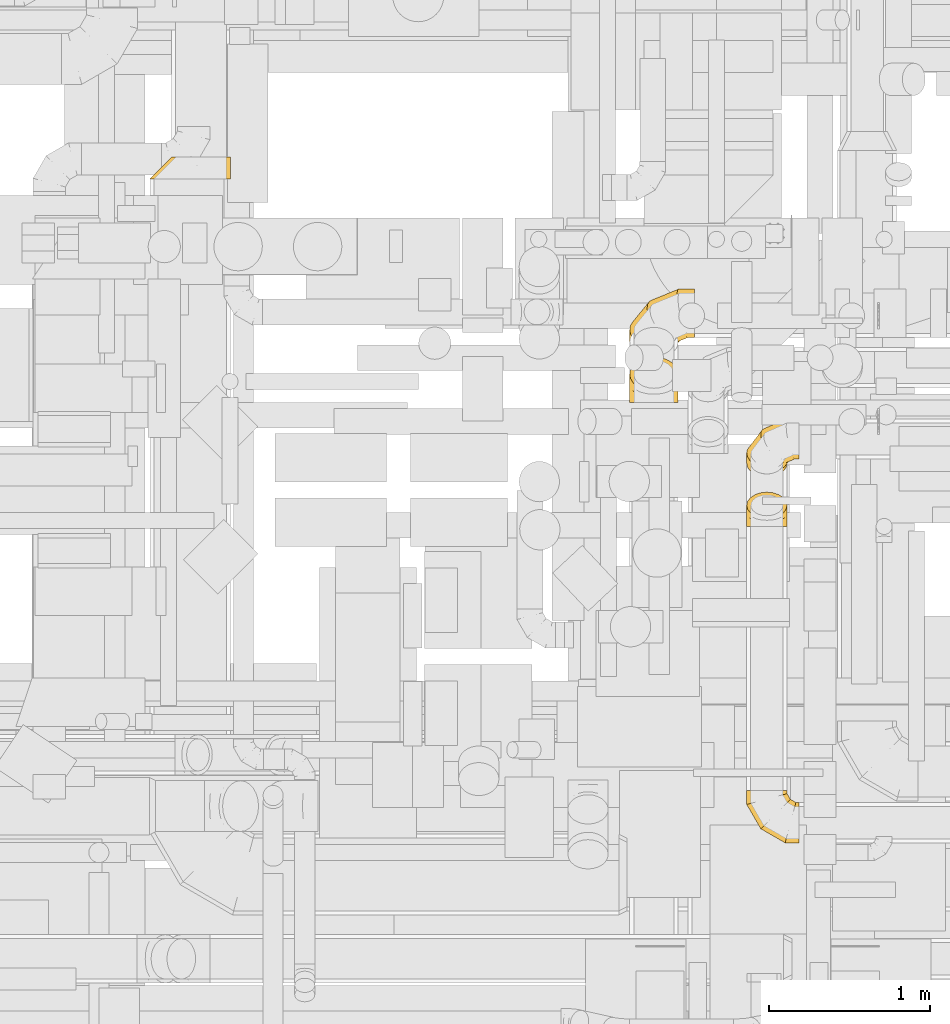
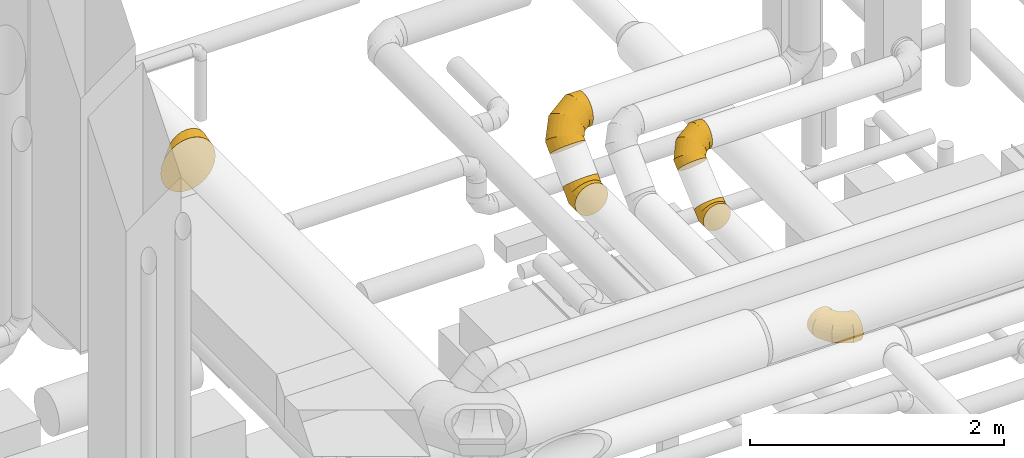
# One storey, part 9 of 337: 6 coverings.
"""IFC2X3 building model written with IfcOpenShell, lengths in millimetres."""

from ifc_helpers import new_model, entity, si_unit, converted_unit, derived_unit, direction, frame, origin, place, context, subcontext, project, spatial, faceted_brep, element, save


model = new_model("IFC2X3")

# Units and contexts
model_context = context("Model", 3, precision=0.01, world=origin(), true_north=direction((6.12303176911189e-17, 1.0)))
body_context = subcontext(model_context, "Body", "Model", "MODEL_VIEW")
ifc_project = project(units=[si_unit("LENGTHUNIT", "METRE", prefix="MILLI"), si_unit("AREAUNIT", "SQUARE_METRE"), si_unit("VOLUMEUNIT", "CUBIC_METRE"), converted_unit("PLANEANGLEUNIT", "DEGREE", entity("IfcRatioMeasure", 0.0174532925199433), si_unit("PLANEANGLEUNIT", "RADIAN"), dimensions=[0, 0, 0, 0, 0, 0, 0]), si_unit("MASSUNIT", "GRAM", prefix="KILO"), derived_unit("MASSDENSITYUNIT", [(si_unit("MASSUNIT", "GRAM", prefix="KILO"), 1), (si_unit("LENGTHUNIT", "METRE"), -3)]), derived_unit("MOMENTOFINERTIAUNIT", [(si_unit("LENGTHUNIT", "METRE"), 4)]), si_unit("TIMEUNIT", "SECOND"), si_unit("FREQUENCYUNIT", "HERTZ"), si_unit("THERMODYNAMICTEMPERATUREUNIT", "DEGREE_CELSIUS"), derived_unit("THERMALTRANSMITTANCEUNIT", [(si_unit("MASSUNIT", "GRAM", prefix="KILO"), 1), (si_unit("THERMODYNAMICTEMPERATUREUNIT", "KELVIN"), -1), (si_unit("TIMEUNIT", "SECOND"), -3)]), derived_unit("VOLUMETRICFLOWRATEUNIT", [(si_unit("LENGTHUNIT", "METRE"), 3), (si_unit("TIMEUNIT", "SECOND"), -1)]), derived_unit("MASSFLOWRATEUNIT", [(si_unit("MASSUNIT", "GRAM", prefix="KILO"), 1), (si_unit("TIMEUNIT", "SECOND"), -1)]), derived_unit("ROTATIONALFREQUENCYUNIT", [(si_unit("TIMEUNIT", "SECOND"), -1)]), si_unit("ELECTRICCURRENTUNIT", "AMPERE"), si_unit("ELECTRICVOLTAGEUNIT", "VOLT"), si_unit("POWERUNIT", "WATT"), si_unit("FORCEUNIT", "NEWTON", prefix="KILO"), si_unit("ILLUMINANCEUNIT", "LUX"), si_unit("LUMINOUSFLUXUNIT", "LUMEN"), si_unit("LUMINOUSINTENSITYUNIT", "CANDELA"), derived_unit("USERDEFINED", [(si_unit("MASSUNIT", "GRAM", prefix="KILO"), -1), (si_unit("LENGTHUNIT", "METRE"), -2), (si_unit("TIMEUNIT", "SECOND"), 3), (si_unit("LUMINOUSFLUXUNIT", "LUMEN"), 1)]), derived_unit("LINEARVELOCITYUNIT", [(si_unit("LENGTHUNIT", "METRE"), 1), (si_unit("TIMEUNIT", "SECOND"), -1)]), si_unit("PRESSUREUNIT", "PASCAL"), derived_unit("USERDEFINED", [(si_unit("LENGTHUNIT", "METRE"), -2), (si_unit("MASSUNIT", "GRAM", prefix="KILO"), 1), (si_unit("TIMEUNIT", "SECOND"), -2)]), derived_unit("LINEARFORCEUNIT", [(si_unit("MASSUNIT", "GRAM", prefix="KILO"), 1), (si_unit("LENGTHUNIT", "METRE"), 1), (si_unit("TIMEUNIT", "SECOND"), -2), (si_unit("LENGTHUNIT", "METRE"), -1)]), derived_unit("PLANARFORCEUNIT", [(si_unit("MASSUNIT", "GRAM", prefix="KILO"), 1), (si_unit("LENGTHUNIT", "METRE"), 1), (si_unit("TIMEUNIT", "SECOND"), -2), (si_unit("LENGTHUNIT", "METRE"), -2)])], contexts=[model_context])

# Site, building, storey
site_placement = place(None, origin())
site = spatial("IfcSite", under=ifc_project, at=site_placement, CompositionType="ELEMENT")
building_placement = place(site_placement, origin())
building = spatial("IfcBuilding", under=site, at=building_placement, CompositionType="ELEMENT")
storey_placement = place(building_placement, origin())
storey = spatial("IfcBuildingStorey", under=building, at=storey_placement, CompositionType="ELEMENT", Elevation=0.0)

# Coverings
covering_1_placement = place(storey_placement, frame((46603.62, 13417.42, 3249.66)))
element("IfcCovering", 1, at=covering_1_placement, inside=storey, PredefinedType="INSULATION", context=body_context, shape_type="Brep", body=[
    faceted_brep([(143.12, 0.0, 476.84), (95.72, 0.0, 447.05), (56.14, 0.0, 407.47), (26.35, 0.0, 360.07), (7.86, 0.0, 307.23), (1.6, 0.0, 251.6), (7.86, 0.0, 195.97), (26.35, 0.0, 143.12), (56.14, 0.0, 95.72), (95.72, 0.0, 56.14), (143.12, 0.0, 26.35), (195.97, 0.0, 7.86), (251.6, 0.0, 1.6), (307.23, 0.0, 7.86), (360.07, 0.0, 26.35), (407.47, 0.0, 56.14), (447.05, 0.0, 95.72), (476.84, 0.0, 143.12), (495.33, 0.0, 195.97), (501.6, 0.0, 251.6), (495.33, 0.0, 307.23), (476.84, 0.0, 360.07), (447.05, 0.0, 407.47), (407.47, 0.0, 447.05), (360.07, 0.0, 476.84), (307.23, 0.0, 495.33), (251.6, 0.0, 501.6), (195.97, 0.0, 495.33), (366.33, 135.0, 477.88), (410.35, 135.0, 459.64), (448.14, 135.0, 430.64), (477.14, 135.0, 392.85), (495.38, 135.0, 348.83), (501.6, 135.0, 301.6), (495.38, 135.0, 254.36), (477.14, 135.0, 210.35), (448.14, 135.0, 172.55), (410.35, 135.0, 143.55), (366.33, 135.0, 125.31), (319.1, 135.0, 119.1), (271.86, 135.0, 125.31), (227.85, 135.0, 143.55), (190.05, 135.0, 172.55), (161.05, 135.0, 210.35), (142.81, 135.0, 254.36), (136.6, 135.0, 301.6), (142.81, 135.0, 348.83), (161.05, 135.0, 392.85), (190.05, 135.0, 430.64), (227.85, 135.0, 459.64), (271.86, 135.0, 477.88), (319.1, 135.0, 484.1), (295.29, 87.4, 77.66), (78.18, 64.36, 203.49), (97.6, 62.48, 158.35), (88.99, 87.4, 283.97), (94.97, 93.38, 286.18), (275.6, 48.01, 43.39), (211.84, 64.36, 69.84), (166.45, 62.48, 89.51), (126.35, 63.75, 123.91), (501.6, 53.25, 271.32), (501.6, 48.01, 269.38), (355.72, 64.36, 69.84), (399.22, 62.48, 89.51), (489.37, 64.36, 203.49), (468.06, 62.48, 158.35), (434.77, 63.75, 118.09), (489.37, 64.36, 347.37), (468.06, 62.48, 391.12), (298.28, 93.38, 489.49), (278.22, 53.25, 494.69), (355.72, 64.36, 481.03), (399.22, 62.48, 459.97), (440.59, 63.75, 426.51), (211.84, 64.36, 481.03), (166.45, 62.48, 459.97), (78.18, 64.36, 347.37), (97.6, 62.48, 391.12), (132.17, 63.75, 432.33)], [[[0, 1, 2, 3, 4, 5, 6, 7, 8, 9, 10, 11, 12, 13, 14, 15, 16, 17, 18, 19, 20, 21, 22, 23, 24, 25, 26, 27]], [[28, 29, 30, 31, 32, 33, 34, 35, 36, 37, 38, 39, 40, 41, 42, 43, 44, 45, 46, 47, 48, 49, 50, 51]], [[52, 40, 39]], [[43, 53, 44]], [[54, 53, 43]], [[55, 44, 53]], [[6, 5, 55]], [[44, 55, 56, 45]], [[11, 52, 57, 12]], [[7, 6, 53]], [[54, 8, 7]], [[58, 10, 59]], [[60, 54, 42]], [[53, 54, 7]], [[59, 60, 42]], [[52, 58, 40]], [[41, 40, 58]], [[55, 53, 6]], [[59, 42, 41]], [[9, 59, 10]], [[60, 59, 9]], [[10, 58, 11]], [[52, 11, 58]], [[9, 8, 60]], [[58, 59, 41]], [[60, 8, 54]], [[42, 54, 43]], [[34, 33, 61, 62]], [[37, 63, 38]], [[64, 63, 37]], [[57, 38, 63]], [[13, 12, 57]], [[38, 57, 52, 39]], [[62, 19, 18]], [[14, 13, 63]], [[64, 15, 14]], [[65, 17, 66]], [[67, 64, 36]], [[63, 64, 14]], [[66, 67, 36]], [[62, 65, 34]], [[35, 34, 65]], [[57, 63, 13]], [[66, 36, 35]], [[16, 66, 17]], [[67, 66, 16]], [[17, 65, 18]], [[62, 18, 65]], [[16, 15, 67]], [[65, 66, 35]], [[67, 15, 64]], [[36, 64, 37]], [[61, 68, 20]], [[31, 68, 32]], [[69, 68, 31]], [[61, 32, 68]], [[20, 19, 62, 61]], [[33, 32, 61]], [[28, 51, 70, 71]], [[22, 21, 69]], [[20, 68, 21]], [[72, 24, 73]], [[74, 69, 30]], [[73, 30, 29]], [[73, 74, 30]], [[71, 72, 28]], [[29, 28, 72]], [[30, 69, 31]], [[71, 26, 25]], [[68, 69, 21]], [[23, 73, 24]], [[72, 73, 29]], [[24, 72, 25]], [[71, 25, 72]], [[74, 73, 23]], [[74, 22, 69]], [[23, 22, 74]], [[56, 46, 45]], [[49, 75, 50]], [[76, 75, 49]], [[70, 50, 75]], [[27, 26, 71, 70]], [[51, 50, 70]], [[4, 56, 55, 5]], [[0, 27, 75]], [[76, 1, 0]], [[77, 3, 78]], [[79, 76, 48]], [[75, 76, 0]], [[78, 79, 48]], [[56, 77, 46]], [[47, 46, 77]], [[70, 75, 27]], [[78, 48, 47]], [[2, 78, 3]], [[79, 78, 2]], [[3, 77, 4]], [[56, 4, 77]], [[2, 1, 79]], [[77, 78, 47]], [[79, 1, 76]], [[48, 76, 49]]]),
])
covering_2_placement = place(storey_placement, frame((50300.56, 9303.36, 2923.4)))
element("IfcCovering", 2, at=covering_2_placement, inside=storey, PredefinedType="INSULATION", context=body_context, shape_type="Brep", body=[
    faceted_brep([(326.6, 165.22, 245.48), (326.6, 126.6, 251.6), (326.6, 87.97, 245.48), (326.6, 53.12, 227.72), (326.6, 25.47, 200.07), (326.6, 7.71, 165.22), (326.6, 1.6, 126.6), (326.6, 7.71, 87.97), (326.6, 25.47, 53.12), (326.6, 53.12, 25.47), (326.6, 87.97, 7.71), (326.6, 126.6, 1.6), (326.6, 165.22, 7.71), (326.6, 200.07, 25.47), (326.6, 227.72, 53.12), (326.6, 245.48, 87.97), (326.6, 251.6, 126.6), (326.6, 245.48, 165.22), (326.6, 227.72, 200.07), (326.6, 200.07, 227.72), (18.34, 326.6, 64.1), (5.85, 326.6, 94.24), (1.6, 326.6, 126.6), (5.85, 326.6, 158.95), (18.34, 326.6, 189.1), (38.21, 326.6, 214.98), (64.1, 326.6, 234.85), (94.24, 326.6, 247.34), (126.6, 326.6, 251.6), (158.95, 326.6, 247.34), (189.1, 326.6, 234.85), (214.98, 326.6, 214.98), (234.85, 326.6, 189.1), (247.34, 326.6, 158.95), (251.6, 326.6, 126.6), (247.34, 326.6, 94.24), (234.85, 326.6, 64.1), (214.98, 326.6, 38.21), (189.1, 326.6, 18.34), (158.95, 326.6, 5.85), (126.6, 326.6, 1.6), (94.24, 326.6, 5.85), (64.1, 326.6, 18.34), (38.21, 326.6, 38.21), (1.6, 239.51, 126.6), (5.85, 240.65, 158.95), (18.34, 244.0, 189.1), (38.21, 249.32, 214.98), (64.1, 256.26, 234.85), (94.24, 264.34, 247.34), (126.6, 273.01, 251.6), (158.95, 281.67, 247.34), (189.1, 289.75, 234.85), (214.98, 296.69, 214.98), (234.85, 302.01, 189.1), (247.34, 305.36, 158.95), (251.6, 306.5, 126.6), (247.34, 305.36, 94.24), (234.85, 302.01, 64.1), (214.98, 296.69, 38.21), (158.95, 281.67, 5.85), (126.6, 273.01, 1.6), (189.1, 289.75, 18.34), (94.24, 264.34, 5.85), (64.1, 256.26, 18.34), (38.21, 249.32, 38.21), (18.34, 244.0, 64.1), (5.85, 240.65, 94.24), (88.68, 88.68, 126.6), (91.8, 91.8, 158.95), (100.94, 100.94, 189.1), (115.48, 115.48, 214.98), (134.43, 134.43, 234.85), (156.5, 156.5, 247.34), (180.19, 180.19, 251.6), (203.87, 203.87, 247.34), (225.94, 225.94, 234.85), (244.89, 244.89, 214.98), (259.43, 259.43, 189.1), (268.57, 268.57, 158.95), (271.69, 271.69, 126.6), (268.57, 268.57, 94.24), (259.43, 259.43, 64.1), (244.89, 244.89, 38.21), (203.87, 203.87, 5.85), (180.19, 180.19, 1.6), (225.94, 225.94, 18.34), (156.5, 156.5, 5.85), (134.43, 134.43, 18.34), (115.48, 115.48, 38.21), (100.94, 100.94, 64.1), (91.8, 91.8, 94.24), (239.51, 1.6, 126.6), (240.65, 5.85, 158.95), (244.0, 18.34, 189.1), (249.32, 38.21, 214.98), (256.26, 64.1, 234.85), (264.34, 94.24, 247.34), (273.01, 126.6, 251.6), (281.67, 158.95, 247.34), (289.75, 189.1, 234.85), (296.69, 214.98, 214.98), (302.01, 234.85, 189.1), (305.36, 247.34, 158.95), (306.5, 251.6, 126.6), (305.36, 247.34, 94.24), (302.01, 234.85, 64.1), (296.69, 214.98, 38.21), (281.67, 158.95, 5.85), (273.01, 126.6, 1.6), (289.75, 189.1, 18.34), (264.34, 94.24, 5.85), (256.26, 64.1, 18.34), (249.32, 38.21, 38.21), (244.0, 18.34, 64.1), (240.65, 5.85, 94.24)], [[[0, 1, 2, 3, 4, 5, 6, 7, 8, 9, 10, 11, 12, 13, 14, 15, 16, 17, 18, 19]], [[20, 21, 22, 23, 24, 25, 26, 27, 28, 29, 30, 31, 32, 33, 34, 35, 36, 37, 38, 39, 40, 41, 42, 43]], [[22, 44, 45, 23]], [[23, 45, 46, 24]], [[47, 25, 24, 46]], [[25, 47, 48, 26]], [[26, 48, 49, 27]], [[50, 28, 27, 49]], [[51, 52, 30, 29]], [[50, 51, 29, 28]], [[53, 31, 30, 52]], [[54, 55, 33, 32]], [[54, 32, 31, 53]], [[56, 34, 33, 55]], [[57, 58, 36, 35]], [[56, 57, 35, 34]], [[37, 36, 58, 59]], [[60, 61, 40, 39]], [[62, 60, 39, 38]], [[59, 62, 38, 37]], [[41, 40, 61, 63]], [[42, 41, 63, 64]], [[64, 65, 43, 42]], [[21, 20, 66, 67]], [[22, 21, 67, 44]], [[65, 66, 20, 43]], [[45, 44, 68, 69]], [[46, 45, 69, 70]], [[70, 71, 47, 46]], [[48, 47, 71, 72]], [[49, 48, 72, 73]], [[50, 49, 73, 74]], [[75, 76, 52, 51]], [[74, 75, 51, 50]], [[53, 52, 76, 77]], [[78, 79, 55, 54]], [[77, 78, 54, 53]], [[56, 55, 79, 80]], [[81, 82, 58, 57]], [[80, 81, 57, 56]], [[59, 58, 82, 83]], [[84, 85, 61, 60]], [[86, 84, 60, 62]], [[83, 86, 62, 59]], [[63, 61, 85, 87]], [[64, 63, 87, 88]], [[65, 64, 88, 89]], [[67, 66, 90, 91]], [[44, 67, 91, 68]], [[89, 90, 66, 65]], [[69, 68, 92, 93]], [[70, 69, 93, 94]], [[94, 95, 71, 70]], [[72, 71, 95, 96]], [[73, 72, 96, 97]], [[74, 73, 97, 98]], [[99, 100, 76, 75]], [[98, 99, 75, 74]], [[77, 76, 100, 101]], [[102, 103, 79, 78]], [[101, 102, 78, 77]], [[80, 79, 103, 104]], [[105, 106, 82, 81]], [[104, 105, 81, 80]], [[83, 82, 106, 107]], [[108, 109, 85, 84]], [[110, 108, 84, 86]], [[107, 110, 86, 83]], [[87, 85, 109, 111]], [[88, 87, 111, 112]], [[89, 88, 112, 113]], [[91, 90, 114, 115]], [[68, 91, 115, 92]], [[113, 114, 90, 89]], [[93, 6, 5]], [[94, 5, 4]], [[6, 93, 92]], [[93, 5, 94]], [[4, 95, 94]], [[96, 3, 2]], [[97, 2, 1]], [[95, 3, 96]], [[96, 2, 97]], [[1, 98, 97]], [[3, 95, 4]], [[99, 1, 0]], [[100, 0, 19]], [[99, 98, 1]], [[100, 99, 0]], [[19, 101, 100]], [[17, 16, 103]], [[18, 17, 102]], [[102, 101, 18]], [[104, 103, 16]], [[102, 17, 103]], [[18, 101, 19]], [[105, 16, 15]], [[106, 15, 14]], [[105, 104, 16]], [[106, 105, 15]], [[14, 107, 106]], [[110, 13, 12]], [[108, 12, 11]], [[110, 107, 13]], [[109, 108, 11]], [[110, 12, 108]], [[13, 107, 14]], [[111, 11, 10]], [[112, 10, 9]], [[11, 111, 109]], [[111, 10, 112]], [[9, 113, 112]], [[114, 8, 7]], [[115, 7, 6]], [[113, 8, 114]], [[115, 114, 7]], [[92, 115, 6]], [[8, 113, 9]]]),
])
covering_3_placement = place(storey_placement, frame((49575.95, 12032.2, 2848.4)))
element("IfcCovering", 3, at=covering_3_placement, inside=storey, PredefinedType="INSULATION", context=body_context, shape_type="Brep", body=[
    faceted_brep([(151.6, 70.71, 330.88), (190.42, 74.32, 327.27), (226.6, 84.92, 316.67), (257.66, 101.78, 299.82), (281.5, 123.74, 277.85), (296.48, 149.32, 252.27), (301.6, 176.78, 224.82), (296.48, 204.23, 197.37), (281.5, 229.81, 171.79), (257.66, 251.78, 149.82), (226.6, 268.63, 132.96), (190.42, 279.23, 122.37), (151.6, 282.84, 118.75), (112.77, 279.23, 122.37), (76.6, 268.63, 132.96), (45.53, 251.78, 149.82), (21.69, 229.81, 171.79), (6.71, 204.23, 197.37), (1.6, 176.78, 224.82), (6.71, 149.32, 252.27), (21.69, 123.74, 277.85), (45.53, 101.78, 299.82), (76.6, 84.92, 316.67), (112.77, 74.32, 327.27), (76.6, 0.0, 21.69), (112.77, 0.0, 6.71), (151.6, 0.0, 1.6), (190.42, 0.0, 6.71), (226.6, 0.0, 21.69), (257.66, 0.0, 45.53), (281.5, 0.0, 76.6), (296.48, 0.0, 112.77), (301.6, 0.0, 151.6), (296.48, 0.0, 190.42), (281.5, 0.0, 226.6), (257.66, 0.0, 257.66), (226.6, 0.0, 281.5), (190.42, 0.0, 296.48), (151.6, 0.0, 301.6), (112.77, 0.0, 296.48), (76.6, 0.0, 281.5), (45.53, 0.0, 257.66), (21.69, 0.0, 226.6), (6.71, 0.0, 190.42), (1.6, 0.0, 151.6), (6.71, 0.0, 112.77), (21.69, 0.0, 76.6), (45.53, 0.0, 45.53), (151.6, 165.69, 1.6), (190.42, 163.57, 6.71), (226.6, 157.36, 21.69), (257.66, 147.49, 45.53), (281.5, 134.62, 76.6), (296.48, 119.63, 112.77), (301.6, 103.55, 151.6), (296.48, 87.47, 190.42), (281.5, 72.49, 226.6), (257.66, 59.62, 257.66), (190.42, 43.54, 296.48), (151.6, 41.42, 301.6), (226.6, 49.75, 281.5), (76.6, 49.75, 281.5), (45.53, 59.62, 257.66), (112.77, 43.54, 296.48), (6.71, 87.47, 190.42), (1.6, 103.55, 151.6), (21.69, 72.49, 226.6), (6.71, 119.63, 112.77), (21.69, 134.62, 76.6), (45.53, 147.49, 45.53), (76.6, 157.36, 21.69), (112.77, 163.57, 6.71)], [[[0, 1, 2, 3, 4, 5, 6, 7, 8, 9, 10, 11, 12, 13, 14, 15, 16, 17, 18, 19, 20, 21, 22, 23]], [[24, 25, 26, 27, 28, 29, 30, 31, 32, 33, 34, 35, 36, 37, 38, 39, 40, 41, 42, 43, 44, 45, 46, 47]], [[26, 48, 49, 27]], [[27, 49, 50, 28]], [[51, 29, 28, 50]], [[29, 51, 52, 30]], [[30, 52, 53, 31]], [[54, 32, 31, 53]], [[55, 56, 34, 33]], [[54, 55, 33, 32]], [[34, 56, 57, 35]], [[58, 59, 38, 37]], [[60, 58, 37, 36]], [[35, 57, 60, 36]], [[40, 61, 62, 41]], [[63, 61, 40, 39]], [[38, 59, 63, 39]], [[64, 65, 44, 43]], [[66, 64, 43, 42]], [[62, 66, 42, 41]], [[45, 44, 65, 67]], [[46, 45, 67, 68]], [[68, 69, 47, 46]], [[25, 24, 70, 71]], [[26, 25, 71, 48]], [[69, 70, 24, 47]], [[11, 10, 50, 49]], [[12, 11, 49, 48]], [[10, 9, 51, 50]], [[53, 52, 8, 7]], [[54, 53, 7, 6]], [[9, 8, 52, 51]], [[5, 4, 56, 55]], [[6, 5, 55, 54]], [[57, 56, 4, 3]], [[58, 60, 2, 1]], [[59, 58, 1, 0]], [[3, 2, 60, 57]], [[59, 0, 23, 63]], [[63, 23, 22, 61]], [[21, 62, 61, 22]], [[66, 20, 19, 64]], [[64, 19, 18, 65]], [[20, 66, 62, 21]], [[65, 18, 17, 67]], [[67, 17, 16, 68]], [[15, 69, 68, 16]], [[70, 14, 13, 71]], [[71, 13, 12, 48]], [[14, 70, 69, 15]]]),
])
covering_4_placement = place(storey_placement, frame((49575.95, 12301.32, 3165.56)))
element("IfcCovering", 4, at=covering_4_placement, inside=storey, PredefinedType="INSULATION", context=body_context, shape_type="Brep", body=[
    faceted_brep([(151.6, 1.6, 213.73), (112.77, 5.21, 210.11), (76.6, 15.81, 199.52), (45.53, 32.66, 182.66), (21.69, 54.63, 160.69), (6.71, 80.21, 135.11), (1.6, 107.66, 107.66), (6.71, 135.11, 80.21), (21.69, 160.69, 54.63), (45.53, 182.66, 32.66), (76.6, 199.52, 15.81), (112.77, 210.11, 5.21), (151.6, 213.73, 1.6), (190.42, 210.11, 5.21), (226.6, 199.52, 15.81), (257.66, 182.66, 32.66), (281.5, 160.69, 54.63), (296.48, 135.11, 80.21), (301.6, 107.66, 107.66), (296.48, 80.21, 135.11), (281.5, 54.63, 160.69), (257.66, 32.66, 182.66), (226.6, 15.81, 199.52), (190.42, 5.21, 210.11), (401.6, 414.34, 359.44), (401.6, 390.5, 390.5), (401.6, 359.44, 414.34), (401.6, 323.26, 429.33), (401.6, 284.44, 434.44), (401.6, 245.62, 429.33), (401.6, 209.44, 414.34), (401.6, 178.37, 390.5), (401.6, 154.53, 359.44), (401.6, 139.55, 323.26), (401.6, 134.44, 284.44), (401.6, 139.55, 245.62), (401.6, 154.53, 209.44), (401.6, 178.37, 178.37), (401.6, 209.44, 154.53), (401.6, 245.62, 139.55), (401.6, 284.44, 134.44), (401.6, 323.26, 139.55), (401.6, 359.44, 154.53), (401.6, 390.5, 178.37), (401.6, 414.34, 209.44), (401.6, 429.33, 245.62), (401.6, 434.44, 284.44), (401.6, 429.33, 323.26), (294.42, 390.5, 390.5), (295.79, 359.44, 414.34), (299.8, 323.26, 429.33), (306.19, 284.44, 434.44), (314.51, 245.62, 429.33), (324.21, 209.44, 414.34), (334.61, 178.37, 390.5), (345.01, 154.53, 359.44), (354.7, 139.55, 323.26), (363.03, 134.44, 284.44), (369.42, 139.55, 245.62), (373.43, 154.53, 209.44), (374.8, 178.37, 178.37), (373.43, 209.44, 154.53), (369.42, 245.62, 139.55), (363.03, 284.44, 134.44), (345.01, 359.44, 154.53), (334.61, 390.5, 178.37), (354.7, 323.26, 139.55), (324.21, 414.34, 209.44), (314.51, 429.33, 245.62), (306.19, 434.44, 284.44), (299.8, 429.33, 323.26), (295.79, 414.34, 359.44), (108.77, 314.72, 314.72), (112.52, 284.62, 339.52), (123.49, 251.28, 357.35), (140.94, 216.97, 366.97), (163.68, 184.04, 367.75), (190.16, 154.72, 359.62), (218.58, 131.0, 343.14), (247.0, 114.52, 319.43), (273.49, 106.39, 290.1), (296.23, 107.17, 257.17), (313.68, 116.79, 222.86), (324.65, 134.62, 189.52), (328.39, 159.43, 159.43), (324.65, 189.52, 134.62), (313.68, 222.86, 116.79), (296.23, 257.17, 107.17), (247.0, 319.43, 114.52), (218.58, 343.14, 131.0), (273.49, 290.1, 106.39), (190.16, 359.62, 154.72), (163.68, 367.75, 184.04), (140.94, 366.97, 216.97), (123.49, 357.35, 251.28), (112.52, 339.52, 284.62), (1.6, 183.45, 183.45), (6.71, 155.03, 209.93), (21.69, 126.61, 232.67), (45.53, 100.12, 250.12), (76.6, 77.38, 261.09), (112.77, 59.93, 264.84), (151.6, 48.96, 261.09), (190.42, 45.22, 250.12), (226.6, 48.96, 232.67), (257.66, 59.93, 209.93), (281.5, 77.38, 183.45), (296.48, 100.12, 155.03), (301.6, 126.61, 126.61), (296.48, 155.03, 100.12), (281.5, 183.45, 77.38), (257.66, 209.93, 59.93), (190.42, 250.12, 45.22), (151.6, 261.09, 48.96), (226.6, 232.67, 48.96), (112.77, 264.84, 59.93), (76.6, 261.09, 77.38), (45.53, 250.12, 100.12), (21.69, 232.67, 126.61), (6.71, 209.93, 155.03)], [[[0, 1, 2, 3, 4, 5, 6, 7, 8, 9, 10, 11, 12, 13, 14, 15, 16, 17, 18, 19, 20, 21, 22, 23]], [[24, 25, 26, 27, 28, 29, 30, 31, 32, 33, 34, 35, 36, 37, 38, 39, 40, 41, 42, 43, 44, 45, 46, 47]], [[25, 48, 49, 26]], [[26, 49, 50, 27]], [[51, 28, 27, 50]], [[28, 51, 52, 29]], [[29, 52, 53, 30]], [[54, 31, 30, 53]], [[55, 56, 33, 32]], [[54, 55, 32, 31]], [[57, 34, 33, 56]], [[58, 59, 36, 35]], [[58, 35, 34, 57]], [[60, 37, 36, 59]], [[61, 62, 39, 38]], [[60, 61, 38, 37]], [[40, 39, 62, 63]], [[64, 65, 43, 42]], [[66, 64, 42, 41]], [[63, 66, 41, 40]], [[44, 43, 65, 67]], [[45, 44, 67, 68]], [[68, 69, 46, 45]], [[24, 47, 70, 71]], [[25, 24, 71, 48]], [[69, 70, 47, 46]], [[49, 48, 72, 73]], [[50, 49, 73, 74]], [[74, 75, 51, 50]], [[52, 51, 75, 76]], [[53, 52, 76, 77]], [[54, 53, 77, 78]], [[79, 80, 56, 55]], [[78, 79, 55, 54]], [[57, 56, 80, 81]], [[82, 83, 59, 58]], [[81, 82, 58, 57]], [[60, 59, 83, 84]], [[85, 86, 62, 61]], [[84, 85, 61, 60]], [[63, 62, 86, 87]], [[88, 89, 65, 64]], [[90, 88, 64, 66]], [[87, 90, 66, 63]], [[67, 65, 89, 91]], [[68, 67, 91, 92]], [[69, 68, 92, 93]], [[71, 70, 94, 95]], [[48, 71, 95, 72]], [[93, 94, 70, 69]], [[73, 72, 96, 97]], [[74, 73, 97, 98]], [[98, 99, 75, 74]], [[76, 75, 99, 100]], [[77, 76, 100, 101]], [[78, 77, 101, 102]], [[103, 104, 80, 79]], [[102, 103, 79, 78]], [[81, 80, 104, 105]], [[106, 107, 83, 82]], [[105, 106, 82, 81]], [[84, 83, 107, 108]], [[109, 110, 86, 85]], [[108, 109, 85, 84]], [[87, 86, 110, 111]], [[112, 113, 89, 88]], [[114, 112, 88, 90]], [[111, 114, 90, 87]], [[91, 89, 113, 115]], [[92, 91, 115, 116]], [[93, 92, 116, 117]], [[95, 94, 118, 119]], [[72, 95, 119, 96]], [[117, 118, 94, 93]], [[97, 96, 6, 5]], [[98, 97, 5, 4]], [[4, 3, 99, 98]], [[101, 100, 2, 1]], [[102, 101, 1, 0]], [[3, 2, 100, 99]], [[103, 102, 0, 23]], [[104, 103, 23, 22]], [[105, 104, 22, 21]], [[107, 106, 20, 19]], [[108, 107, 19, 18]], [[105, 21, 20, 106]], [[108, 18, 17, 109]], [[109, 17, 16, 110]], [[110, 16, 15, 111]], [[13, 12, 113, 112]], [[14, 13, 112, 114]], [[114, 111, 15, 14]], [[113, 12, 11, 115]], [[115, 11, 10, 116]], [[9, 117, 116, 10]], [[118, 8, 7, 119]], [[119, 7, 6, 96]], [[8, 118, 117, 9]]]),
])
covering_5_placement = place(storey_placement, frame((50300.56, 11572.15, 3223.36)))
element("IfcCovering", 5, at=covering_5_placement, inside=storey, PredefinedType="INSULATION", context=body_context, shape_type="Brep", body=[
    faceted_brep([(200.07, 17.13, 173.34), (165.22, 5.58, 186.82), (126.6, 1.6, 191.47), (87.97, 5.58, 186.82), (53.12, 17.13, 173.34), (25.47, 35.11, 152.33), (7.71, 57.78, 125.87), (1.6, 82.91, 96.53), (7.71, 108.04, 67.19), (25.47, 130.71, 40.73), (53.12, 148.7, 19.73), (87.97, 160.25, 6.24), (126.6, 164.23, 1.6), (165.22, 160.25, 6.24), (200.07, 148.7, 19.73), (227.72, 130.71, 40.73), (245.48, 108.04, 67.19), (251.6, 82.91, 96.53), (245.48, 57.78, 125.87), (227.72, 35.11, 152.33), (326.6, 357.68, 249.59), (326.6, 347.55, 280.61), (326.6, 329.74, 307.95), (326.6, 305.46, 329.75), (326.6, 276.37, 344.52), (326.6, 244.44, 351.26), (326.6, 211.85, 349.51), (326.6, 180.83, 339.38), (326.6, 153.49, 321.57), (326.6, 131.69, 297.29), (326.6, 116.92, 268.19), (326.6, 110.18, 236.27), (326.6, 111.93, 203.68), (326.6, 122.06, 172.66), (326.6, 139.87, 145.32), (326.6, 164.15, 123.52), (326.6, 193.25, 108.75), (326.6, 225.18, 102.01), (326.6, 257.76, 103.76), (326.6, 288.78, 113.89), (326.6, 316.12, 131.7), (326.6, 337.92, 155.98), (326.6, 352.7, 185.08), (326.6, 359.44, 217.0), (239.51, 329.74, 307.95), (240.65, 305.46, 329.75), (244.0, 276.37, 344.52), (249.32, 244.44, 351.26), (256.26, 211.85, 349.51), (264.34, 180.83, 339.38), (273.01, 153.49, 321.57), (281.67, 131.69, 297.29), (289.75, 116.92, 268.19), (296.69, 110.18, 236.27), (302.01, 111.93, 203.68), (305.36, 122.06, 172.66), (306.5, 139.87, 145.32), (305.36, 164.15, 123.52), (302.01, 193.25, 108.75), (296.69, 225.18, 102.01), (281.67, 288.78, 113.89), (273.01, 316.12, 131.7), (289.75, 257.76, 103.76), (264.34, 337.92, 155.98), (256.26, 352.7, 185.08), (249.32, 359.44, 217.0), (244.0, 357.68, 249.59), (240.65, 347.55, 280.61), (88.68, 263.61, 251.3), (91.8, 240.19, 273.84), (100.94, 213.64, 290.79), (115.48, 185.75, 301.0), (134.43, 158.44, 303.75), (156.5, 133.55, 298.88), (180.19, 112.79, 286.71), (203.87, 97.58, 268.07), (225.94, 88.94, 244.23), (244.89, 87.47, 216.81), (259.43, 93.26, 187.69), (268.57, 105.93, 158.85), (271.69, 124.61, 132.25), (268.57, 148.02, 109.7), (259.43, 174.58, 92.75), (244.89, 202.46, 82.55), (203.87, 254.66, 84.67), (180.19, 275.42, 96.84), (225.94, 229.78, 79.79), (156.5, 290.64, 115.48), (134.43, 299.28, 139.32), (115.48, 300.75, 166.74), (100.94, 294.95, 195.86), (91.8, 282.28, 224.7), (1.6, 149.05, 153.18), (5.85, 127.14, 177.01), (18.34, 104.98, 197.73), (38.21, 84.1, 213.93), (64.1, 65.91, 224.5), (94.24, 51.65, 228.73), (126.6, 42.3, 226.33), (158.95, 38.48, 217.45), (189.1, 40.47, 202.72), (214.98, 48.13, 183.12), (234.85, 60.92, 159.99), (247.34, 77.99, 134.92), (251.6, 98.17, 109.6), (247.34, 120.09, 85.78), (234.85, 142.24, 65.06), (214.98, 163.12, 48.86), (158.95, 195.57, 34.05), (126.6, 204.93, 36.46), (189.1, 181.31, 38.28), (94.24, 208.74, 45.33), (64.1, 206.75, 60.07), (38.21, 199.1, 79.67), (18.34, 186.3, 102.79), (5.85, 169.23, 127.87)], [[[0, 1, 2, 3, 4, 5, 6, 7, 8, 9, 10, 11, 12, 13, 14, 15, 16, 17, 18, 19]], [[20, 21, 22, 23, 24, 25, 26, 27, 28, 29, 30, 31, 32, 33, 34, 35, 36, 37, 38, 39, 40, 41, 42, 43]], [[22, 44, 45, 23]], [[23, 45, 46, 24]], [[47, 25, 24, 46]], [[25, 47, 48, 26]], [[26, 48, 49, 27]], [[50, 28, 27, 49]], [[51, 52, 30, 29]], [[50, 51, 29, 28]], [[53, 31, 30, 52]], [[54, 55, 33, 32]], [[54, 32, 31, 53]], [[56, 34, 33, 55]], [[57, 58, 36, 35]], [[56, 57, 35, 34]], [[37, 36, 58, 59]], [[60, 61, 40, 39]], [[62, 60, 39, 38]], [[59, 62, 38, 37]], [[41, 40, 61, 63]], [[42, 41, 63, 64]], [[64, 65, 43, 42]], [[21, 20, 66, 67]], [[22, 21, 67, 44]], [[65, 66, 20, 43]], [[45, 44, 68, 69]], [[46, 45, 69, 70]], [[70, 71, 47, 46]], [[48, 47, 71, 72]], [[49, 48, 72, 73]], [[50, 49, 73, 74]], [[75, 76, 52, 51]], [[74, 75, 51, 50]], [[53, 52, 76, 77]], [[78, 79, 55, 54]], [[77, 78, 54, 53]], [[56, 55, 79, 80]], [[81, 82, 58, 57]], [[80, 81, 57, 56]], [[59, 58, 82, 83]], [[84, 85, 61, 60]], [[86, 84, 60, 62]], [[83, 86, 62, 59]], [[63, 61, 85, 87]], [[64, 63, 87, 88]], [[65, 64, 88, 89]], [[67, 66, 90, 91]], [[44, 67, 91, 68]], [[89, 90, 66, 65]], [[69, 68, 92, 93]], [[70, 69, 93, 94]], [[94, 95, 71, 70]], [[72, 71, 95, 96]], [[73, 72, 96, 97]], [[74, 73, 97, 98]], [[99, 100, 76, 75]], [[98, 99, 75, 74]], [[77, 76, 100, 101]], [[102, 103, 79, 78]], [[101, 102, 78, 77]], [[80, 79, 103, 104]], [[105, 106, 82, 81]], [[104, 105, 81, 80]], [[83, 82, 106, 107]], [[108, 109, 85, 84]], [[110, 108, 84, 86]], [[107, 110, 86, 83]], [[87, 85, 109, 111]], [[88, 87, 111, 112]], [[89, 88, 112, 113]], [[91, 90, 114, 115]], [[68, 91, 115, 92]], [[113, 114, 90, 89]], [[93, 7, 6]], [[94, 6, 5]], [[7, 93, 92]], [[93, 6, 94]], [[5, 95, 94]], [[96, 4, 3]], [[97, 3, 2]], [[95, 4, 96]], [[96, 3, 97]], [[2, 98, 97]], [[4, 95, 5]], [[99, 2, 1]], [[100, 1, 0]], [[99, 98, 2]], [[100, 99, 1]], [[0, 101, 100]], [[18, 17, 103]], [[19, 18, 102]], [[102, 101, 19]], [[104, 103, 17]], [[102, 18, 103]], [[19, 101, 0]], [[105, 17, 16]], [[106, 16, 15]], [[105, 104, 17]], [[106, 105, 16]], [[15, 107, 106]], [[110, 14, 13]], [[108, 13, 12]], [[110, 107, 14]], [[109, 108, 12]], [[110, 13, 108]], [[14, 107, 15]], [[111, 12, 11]], [[112, 11, 10]], [[12, 111, 109]], [[111, 11, 112]], [[10, 113, 112]], [[114, 9, 8]], [[115, 8, 7]], [[113, 9, 114]], [[115, 114, 8]], [[92, 115, 7]], [[9, 113, 10]]]),
])
covering_6_placement = place(storey_placement, frame((50300.56, 11266.01, 2923.4)))
element("IfcCovering", 6, at=covering_6_placement, inside=storey, PredefinedType="INSULATION", context=body_context, shape_type="Brep", body=[
    faceted_brep([(1.6, 130.1, 174.7), (7.71, 104.98, 204.03), (25.47, 82.31, 230.5), (53.12, 64.32, 251.5), (87.97, 52.77, 264.99), (126.6, 48.79, 269.63), (165.22, 52.77, 264.99), (200.07, 64.32, 251.5), (227.72, 82.31, 230.5), (245.48, 104.98, 204.03), (251.6, 130.1, 174.7), (245.48, 155.23, 145.36), (227.72, 177.9, 118.9), (200.07, 195.89, 97.89), (165.22, 207.44, 84.41), (126.6, 211.42, 79.76), (87.97, 207.44, 84.41), (53.12, 195.89, 97.89), (25.47, 177.9, 118.9), (7.71, 155.23, 145.36), (94.24, 0.0, 5.85), (126.6, 0.0, 1.6), (158.95, 0.0, 5.85), (189.1, 0.0, 18.34), (214.98, 0.0, 38.21), (234.85, 0.0, 64.1), (247.34, 0.0, 94.24), (251.6, 0.0, 126.6), (247.34, 0.0, 158.95), (234.85, 0.0, 189.1), (214.98, 0.0, 214.98), (189.1, 0.0, 234.85), (158.95, 0.0, 247.34), (126.6, 0.0, 251.6), (94.24, 0.0, 247.34), (64.1, 0.0, 234.85), (38.21, 0.0, 214.98), (18.34, 0.0, 189.1), (5.85, 0.0, 158.95), (1.6, 0.0, 126.6), (5.85, 0.0, 94.24), (18.34, 0.0, 64.1), (38.21, 0.0, 38.21), (64.1, 0.0, 18.34), (126.6, 120.16, 1.6), (158.95, 118.59, 5.85), (189.1, 113.97, 18.34), (214.98, 106.62, 38.21), (234.85, 97.05, 64.1), (247.34, 85.91, 94.24), (251.6, 73.94, 126.6), (247.34, 61.98, 158.95), (234.85, 50.84, 189.1), (214.98, 41.27, 214.98), (158.95, 29.3, 247.34), (126.6, 27.73, 251.6), (189.1, 33.92, 234.85), (64.1, 33.92, 234.85), (38.21, 41.27, 214.98), (94.24, 29.3, 247.34), (5.85, 61.98, 158.95), (1.6, 73.94, 126.6), (18.34, 50.84, 189.1), (5.85, 85.91, 94.24), (18.34, 97.05, 64.1), (38.21, 106.62, 38.21), (64.1, 113.97, 18.34), (94.24, 118.59, 5.85)], [[[0, 1, 2, 3, 4, 5, 6, 7, 8, 9, 10, 11, 12, 13, 14, 15, 16, 17, 18, 19]], [[20, 21, 22, 23, 24, 25, 26, 27, 28, 29, 30, 31, 32, 33, 34, 35, 36, 37, 38, 39, 40, 41, 42, 43]], [[21, 44, 45, 22]], [[22, 45, 46, 23]], [[47, 24, 23, 46]], [[24, 47, 48, 25]], [[25, 48, 49, 26]], [[50, 27, 26, 49]], [[51, 52, 29, 28]], [[50, 51, 28, 27]], [[29, 52, 53, 30]], [[54, 55, 33, 32]], [[56, 54, 32, 31]], [[30, 53, 56, 31]], [[35, 57, 58, 36]], [[59, 57, 35, 34]], [[33, 55, 59, 34]], [[60, 61, 39, 38]], [[62, 60, 38, 37]], [[58, 62, 37, 36]], [[40, 39, 61, 63]], [[41, 40, 63, 64]], [[64, 65, 42, 41]], [[20, 43, 66, 67]], [[21, 20, 67, 44]], [[65, 66, 43, 42]], [[14, 13, 46]], [[15, 14, 45]], [[15, 45, 44]], [[45, 14, 46]], [[13, 47, 46]], [[48, 12, 11]], [[49, 11, 10]], [[47, 12, 48]], [[48, 11, 49]], [[10, 50, 49]], [[12, 47, 13]], [[51, 10, 9]], [[52, 9, 8]], [[51, 50, 10]], [[52, 51, 9]], [[8, 53, 52]], [[56, 7, 6]], [[54, 6, 5]], [[56, 53, 7]], [[55, 54, 5]], [[56, 6, 54]], [[7, 53, 8]], [[4, 3, 57]], [[5, 4, 59]], [[59, 55, 5]], [[57, 59, 4]], [[3, 58, 57]], [[62, 2, 1]], [[60, 1, 0]], [[62, 58, 2]], [[61, 60, 0]], [[62, 1, 60]], [[2, 58, 3]], [[63, 0, 19]], [[64, 19, 18]], [[0, 63, 61]], [[63, 19, 64]], [[18, 65, 64]], [[66, 17, 16]], [[67, 16, 15]], [[65, 17, 66]], [[67, 66, 16]], [[44, 67, 15]], [[17, 65, 18]]]),
])

save(model, "model.ifc")
